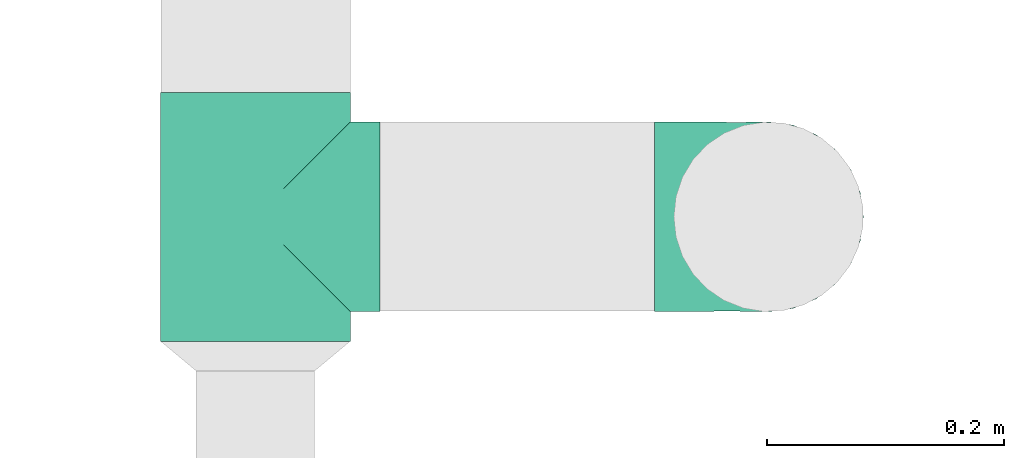
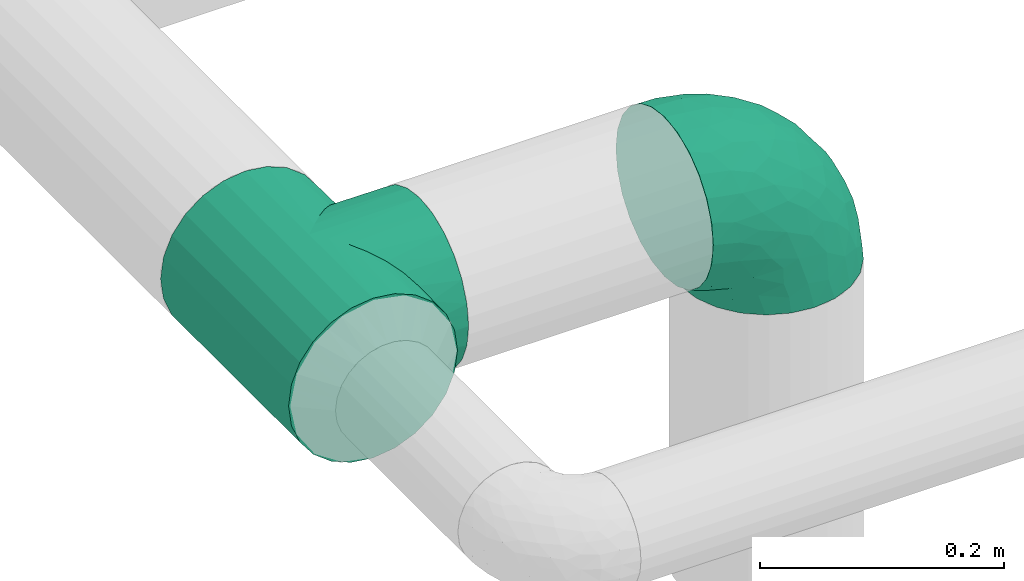
# One storey, part 3 of 12: 2 flow fittings.
"""IFC2X3 building model written with IfcOpenShell, lengths in millimetres."""

import ifcopenshell
import ifcopenshell.guid

model = None  # the IFC model being written
_history = None  # IfcOwnerHistory: only IFC2X3 demands one
_inside = {}  # id of a spatial element -> (the spatial element, [elements in it])
_under = {}  # id of a project, library or spatial element -> (it, [spatial elements below it])
_declared = {}  # id of a project -> (the project, [libraries it declares])
_typed = {}  # id of a type object -> (the type object, [elements of that type])
_made_of = {}  # id of a material, layer set ... -> (it, [elements and type objects made of it])


def new_model(schema):
    """Start an empty IFC model of exactly this schema.

    Asked for "IFC4X3", IfcOpenShell would pick the latest addendum, in which some entities
    have other attributes; the version numbers below select the first issue.
    IFC2X3 requires an IfcOwnerHistory on every rooted entity: one is made here for all.
    """
    global model, _history
    if schema == "IFC4X3":
        model = ifcopenshell.file(schema_version=(4, 3, 0, 0))
    else:
        model = ifcopenshell.file(schema=schema)
    _inside.clear()
    _under.clear()
    _declared.clear()
    _typed.clear()
    _made_of.clear()
    _history = None
    if model.schema == "IFC2X3":
        org = make("IfcOrganization", Name="unknown")
        user = make(
            "IfcPersonAndOrganization",
            ThePerson=make("IfcPerson", FamilyName="unknown"),
            TheOrganization=org,
        )
        app = make(
            "IfcApplication",
            ApplicationDeveloper=org,
            Version="unknown",
            ApplicationFullName="unknown",
            ApplicationIdentifier="unknown",
        )
        _history = make(
            "IfcOwnerHistory",
            OwningUser=user,
            OwningApplication=app,
            ChangeAction="ADDED",
            CreationDate=0,
        )
    return model


def make(cls, **values):
    """One entity of the class cls with the attributes given. An attribute that is None is left unset."""
    return model.create_entity(
        cls, **{name: value for name, value in values.items() if value is not None}
    )


def entity(cls, *values):
    """Any entity or typed value of the class cls, its attributes in the order of the schema. None: left unset."""
    e = model.create_entity(cls)
    for i, value in enumerate(values):
        if value is not None:
            e[i] = value
    return e


def rooted(cls, **values):
    """An entity with a GlobalId (a new one), such as an element, a storey or a relation."""
    return make(cls, GlobalId=ifcopenshell.guid.new(), OwnerHistory=_history, **values)


def si_unit(unit_type, name, prefix=None):
    """IfcSIUnit, for example si_unit("LENGTHUNIT", "METRE", prefix="MILLI")."""
    return make("IfcSIUnit", UnitType=unit_type, Prefix=prefix, Name=name)


def converted_unit(unit_type, name, factor, base, dimensions=None, offset=None):
    """IfcConversionBasedUnit, such as the inch: factor (a typed value) times the base unit."""
    return make(
        "IfcConversionBasedUnit"
        if offset is None
        else "IfcConversionBasedUnitWithOffset",
        ConversionOffset=offset,
        Dimensions=None
        if dimensions is None
        else entity("IfcDimensionalExponents", *dimensions),
        UnitType=unit_type,
        Name=name,
        ConversionFactor=make(
            "IfcMeasureWithUnit", ValueComponent=factor, UnitComponent=base
        ),
    )


def derived_unit(unit_type, elements):
    """IfcDerivedUnit: a product of units, each with its exponent."""
    return make(
        "IfcDerivedUnit",
        Elements=[
            make("IfcDerivedUnitElement", Unit=unit, Exponent=power)
            for unit, power in elements
        ],
        UnitType=unit_type,
    )


def assignment(units):
    """IfcUnitAssignment: the units of a project."""
    return None if units is None else make("IfcUnitAssignment", Units=units)


def point(xyz):
    """IfcCartesianPoint."""
    return None if xyz is None else make("IfcCartesianPoint", Coordinates=xyz)


def direction(xyz):
    """IfcDirection."""
    return None if xyz is None else make("IfcDirection", DirectionRatios=xyz)


def frame(location, z_axis=None, x_axis=None):
    """IfcAxis2Placement3D, a coordinate frame: its origin and axes. An axis left out is left unset."""
    return make(
        "IfcAxis2Placement3D",
        Location=point(location),
        Axis=direction(z_axis),
        RefDirection=direction(x_axis),
    )


def origin():
    """The frame at (0, 0, 0) with its axes left unset."""
    return frame((0.0, 0.0, 0.0))


def place(relative_to, where):
    """IfcLocalPlacement: puts the frame where relative to a parent placement (None: the world)."""
    return make(
        "IfcLocalPlacement", PlacementRelTo=relative_to, RelativePlacement=where
    )


def context(
    kind, dimensions, precision=None, world=None, true_north=None, identifier=None
):
    """IfcGeometricRepresentationContext, for example the 3D "Model" context."""
    return make(
        "IfcGeometricRepresentationContext",
        ContextIdentifier=identifier,
        ContextType=kind,
        CoordinateSpaceDimension=dimensions,
        Precision=precision,
        WorldCoordinateSystem=world,
        TrueNorth=true_north,
    )


def subcontext(parent, identifier, kind, view, scale=None):
    """IfcGeometricRepresentationSubContext, for example "Body" below "Model"."""
    return make(
        "IfcGeometricRepresentationSubContext",
        ContextIdentifier=identifier,
        ContextType=kind,
        ParentContext=parent,
        TargetScale=scale,
        TargetView=view,
    )


def project(units=None, contexts=None):
    """IfcProject with its units and contexts."""
    return rooted(
        "IfcProject",
        Name="project",
        RepresentationContexts=contexts,
        UnitsInContext=assignment(units),
    )


def spatial(cls, under=None, at=None, **own):
    """A site, building, storey or space (cls), placed at a placement, below another one or the project."""
    s = rooted(cls, ObjectPlacement=at, **own)
    if under is not None:
        _under.setdefault(under.id(), (under, []))[1].append(s)
    return s


def faces_of(points, faces, orient=None, outer=None):
    """IfcFace entities. A face is a list of loops; a loop is a list of indices into points, from 0.

    orient and outer hold one flag for each loop. By default every Orientation is true, the
    first loop of a face is its IfcFaceOuterBound and the others are IfcFaceBound.
    """
    made = []
    for i, loops in enumerate(faces):
        bounds = []
        for j, loop in enumerate(loops):
            is_outer = j == 0 if outer is None else outer[i][j]
            bounds.append(
                make(
                    "IfcFaceOuterBound" if is_outer else "IfcFaceBound",
                    Bound=make("IfcPolyLoop", Polygon=[points[k] for k in loop]),
                    Orientation=True if orient is None else orient[i][j],
                )
            )
        made.append(make("IfcFace", Bounds=bounds))
    return made


def faceted_brep(points, faces, orient=None, outer=None, voids=None):
    """IfcFacetedBrep: a solid bounded by flat faces; with voids (closed shells), ...WithVoids."""
    shared = [point(p) for p in points]
    hull = make("IfcClosedShell", CfsFaces=faces_of(shared, faces, orient, outer))
    if voids is None:
        return make("IfcFacetedBrep", Outer=hull)
    return make(
        "IfcFacetedBrepWithVoids",
        Outer=hull,
        Voids=[
            make(cls, CfsFaces=faces_of(shared, fs, o, b)) for cls, fs, o, b in voids
        ],
    )


def shape(context_of_items, identifier, shape_type, items):
    """IfcShapeRepresentation: the items that make up one representation, for example the "Body"."""
    return make(
        "IfcShapeRepresentation",
        ContextOfItems=context_of_items,
        RepresentationIdentifier=identifier,
        RepresentationType=shape_type,
        Items=items,
    )


def source(mapping_origin, context_of_items, identifier, shape_type, items):
    """IfcRepresentationMap: a shape defined once, which mapped items show again and again."""
    return make(
        "IfcRepresentationMap",
        MappingOrigin=mapping_origin,
        MappedRepresentation=shape(context_of_items, identifier, shape_type, items),
    )


def transform(
    local_origin,
    x_axis=None,
    y_axis=None,
    z_axis=None,
    scale=None,
    scale2=None,
    scale3=None,
    uniform=True,
):
    """IfcCartesianTransformationOperator3D, or its non-uniform kind. x_axis, y_axis, z_axis: its Axis1, 2, 3."""
    if uniform:
        return make(
            "IfcCartesianTransformationOperator3D",
            Axis1=direction(x_axis),
            Axis2=direction(y_axis),
            LocalOrigin=point(local_origin),
            Scale=scale,
            Axis3=direction(z_axis),
        )
    return make(
        "IfcCartesianTransformationOperator3DnonUniform",
        Axis1=direction(x_axis),
        Axis2=direction(y_axis),
        LocalOrigin=point(local_origin),
        Scale=scale,
        Axis3=direction(z_axis),
        Scale2=scale2,
        Scale3=scale3,
    )


def mapped(mapping_source, mapping_target):
    """IfcMappedItem: shows the shape of a source again, moved by a transform."""
    return make(
        "IfcMappedItem", MappingSource=mapping_source, MappingTarget=mapping_target
    )


def made_of(thing, what):
    """Note that an element or type object is made of a material, layer set ...; save() writes the relation."""
    if what is not None:
        _made_of.setdefault(what.id(), (what, []))[1].append(thing)
    return thing


def type_object(cls, material=None, **own):
    """A type object (cls), such as IfcWallType, which elements share."""
    return made_of(rooted(cls, **own), material)


def type_shapes(of_type, sources):
    """Give a type object the sources (RepresentationMaps) that its elements show as mapped items."""
    of_type.RepresentationMaps = sources


def element(
    cls,
    number,
    at=None,
    inside=None,
    cuts=None,
    type_object=None,
    material=None,
    context=None,
    identifier="Body",
    shape_type=None,
    held_by="IfcProductDefinitionShape",
    body=None,
    shapes=None,
    **own,
):
    """One element of the class cls, such as IfcWall. Its Tag is "e" and its number.

    at: its placement. inside: the storey or other place that contains it. cuts: it is an
    opening in that element (IfcRelVoidsElement). A single representation is given by context,
    identifier, shape_type and body (its items); several are given by shapes. held_by: the class
    of the entity that holds the representations. save() writes the other relations.
    """
    e = rooted(cls, Tag="e%d" % number, ObjectPlacement=at, **own)
    if body is not None:
        shapes = [shape(context, identifier, shape_type, body)]
    if shapes is not None:
        e.Representation = make(held_by, Representations=shapes)
    if inside is not None:
        _inside.setdefault(inside.id(), (inside, []))[1].append(e)
    if cuts is not None:
        rooted(
            "IfcRelVoidsElement", RelatingBuildingElement=cuts, RelatedOpeningElement=e
        )
    if type_object is not None:
        _typed.setdefault(type_object.id(), (type_object, []))[1].append(e)
    return made_of(e, material)


def aggregate(whole, parts):
    """IfcRelAggregates: a whole, such as a stair, and the parts it consists of."""
    return rooted("IfcRelAggregates", RelatingObject=whole, RelatedObjects=parts)


def save(model, path):
    """Write the relations noted so far, then the file.

    IfcRelAggregates (storeys below a building ...), IfcRelContainedInSpatialStructure (elements
    in a storey), IfcRelDefinesByType, IfcRelAssociatesMaterial and IfcRelDeclares: one each for
    every whole, place, type object, material and project.
    """
    for whole, parts in _under.values():
        aggregate(whole, parts)
    for where, things in _inside.values():
        rooted(
            "IfcRelContainedInSpatialStructure",
            RelatedElements=things,
            RelatingStructure=where,
        )
    for kind, things in _typed.values():
        rooted("IfcRelDefinesByType", RelatedObjects=things, RelatingType=kind)
    for what, things in _made_of.values():
        rooted("IfcRelAssociatesMaterial", RelatedObjects=things, RelatingMaterial=what)
    for by, libraries in _declared.values():
        rooted("IfcRelDeclares", RelatingContext=by, RelatedDefinitions=libraries)
    model.write(path)


model = new_model("IFC2X3")

# Units and contexts
model_context = context("Model", 3, precision=0.01, world=origin(), true_north=direction((6.12303176911189e-17, 1.0)))
body_context = subcontext(model_context, "Body", "Model", "MODEL_VIEW")
ifc_project = project(units=[si_unit("LENGTHUNIT", "METRE", prefix="MILLI"), si_unit("AREAUNIT", "SQUARE_METRE"), si_unit("VOLUMEUNIT", "CUBIC_METRE"), converted_unit("PLANEANGLEUNIT", "DEGREE", entity("IfcRatioMeasure", 0.0174532925199433), si_unit("PLANEANGLEUNIT", "RADIAN"), dimensions=[0, 0, 0, 0, 0, 0, 0]), si_unit("MASSUNIT", "GRAM", prefix="KILO"), derived_unit("MASSDENSITYUNIT", [(si_unit("MASSUNIT", "GRAM", prefix="KILO"), 1), (si_unit("LENGTHUNIT", "METRE"), -3)]), si_unit("TIMEUNIT", "SECOND"), si_unit("FREQUENCYUNIT", "HERTZ"), si_unit("THERMODYNAMICTEMPERATUREUNIT", "DEGREE_CELSIUS"), derived_unit("THERMALTRANSMITTANCEUNIT", [(si_unit("MASSUNIT", "GRAM", prefix="KILO"), 1), (si_unit("THERMODYNAMICTEMPERATUREUNIT", "KELVIN"), -1), (si_unit("TIMEUNIT", "SECOND"), -3)]), derived_unit("VOLUMETRICFLOWRATEUNIT", [(si_unit("LENGTHUNIT", "METRE"), 3), (si_unit("TIMEUNIT", "SECOND"), -1)]), si_unit("ELECTRICCURRENTUNIT", "AMPERE"), si_unit("ELECTRICVOLTAGEUNIT", "VOLT"), si_unit("POWERUNIT", "WATT"), si_unit("FORCEUNIT", "NEWTON", prefix="KILO"), si_unit("ILLUMINANCEUNIT", "LUX"), si_unit("LUMINOUSFLUXUNIT", "LUMEN"), si_unit("LUMINOUSINTENSITYUNIT", "CANDELA"), derived_unit("USERDEFINED", [(si_unit("MASSUNIT", "GRAM", prefix="KILO"), -1), (si_unit("LENGTHUNIT", "METRE"), -2), (si_unit("TIMEUNIT", "SECOND"), 3), (si_unit("LUMINOUSFLUXUNIT", "LUMEN"), 1)]), derived_unit("LINEARVELOCITYUNIT", [(si_unit("LENGTHUNIT", "METRE"), 1), (si_unit("TIMEUNIT", "SECOND"), -1)]), si_unit("PRESSUREUNIT", "PASCAL"), derived_unit("USERDEFINED", [(si_unit("LENGTHUNIT", "METRE"), -2), (si_unit("MASSUNIT", "GRAM", prefix="KILO"), 1), (si_unit("TIMEUNIT", "SECOND"), -2)])], contexts=[model_context])

# Site, building, storey
site_placement = place(None, origin())
site = spatial("IfcSite", under=ifc_project, at=site_placement, CompositionType="ELEMENT")
building_placement = place(site_placement, origin())
building = spatial("IfcBuilding", under=site, at=building_placement, CompositionType="ELEMENT")
storey_placement = place(building_placement, frame((0.0, 0.0, 4000.0)))
storey = spatial("IfcBuildingStorey", under=building, at=storey_placement, Name="01 Level", CompositionType="ELEMENT", Elevation=4000.0)

# Flow fittings
duct_fitting_type_1 = type_object("IfcDuctFittingType", Name="Air_Elbow short_Circ", PredefinedType="NOTDEFINED")
shared_shape_1 = source(origin(), body_context, "Body", "Brep", [
    faceted_brep([(-96.0, 40.0, -69.2820323027551), (-96.0, 20.7055236082018, -77.2740661031254), (-96.0, 0.0, -80.0), (-96.0, -20.7055236082015, -77.2740661031255), (-96.0, -40.0, -69.2820323027552), (-96.0, -56.5685424949237, -56.5685424949239), (-96.0, -69.282032302755, -40.0), (-96.0, -77.2740661031254, -20.7055236082019), (-96.0, -80.0, 0.0), (-96.0, -77.2740661031256, 20.7055236082014), (-96.0, -69.2820323027553, 40.0), (-96.0, -56.568542494924, 56.5685424949236), (-96.0, -40.0, 69.2820323027549), (-96.0, -20.705523608202, 77.2740661031254), (-96.0, 0.0, 80.0), (-96.0, 20.7055236082013, 77.2740661031256), (-96.0, 30.3527618041005, 73.2780492029404), (-96.0, 40.0, 69.2820323027553), (-96.0, 56.5685424949235, 56.5685424949241), (-96.0, 69.2820323027549, 40.0), (-96.0, 77.2740661031253, 20.7055236082021), (-96.0, 80.0, 0.0), (-96.0, 77.2740661031255, -20.7055236082016), (-96.0, 69.2820323027551, -40.0), (-96.0, 56.5685424949239, -56.5685424949238), (0.0, 96.0, -80.0), (-20.7055236082008, 96.0, -77.2740661031254), (-30.3527618041, 96.0, -73.2780492029402), (-40.0, 96.0, -69.2820323027551), (-56.5685424949229, 96.0, -56.5685424949238), (-69.2820323027542, 96.0, -40.0), (-77.2740661031245, 96.0, -20.7055236082016), (-80.0, 96.0, 0.0), (-77.2740661031244, 96.0, 20.7055236082021), (-69.2820323027539, 96.0, 40.0), (-56.5685424949226, 96.0, 56.5685424949241), (-40.0, 96.0, 69.2820323027553), (-20.7055236082004, 96.0, 77.2740661031256), (0.0, 96.0, 80.0), (20.7055236082029, 96.0, 77.2740661031254), (40.0, 96.0, 69.2820323027549), (56.5685424949249, 96.0, 56.5685424949236), (69.2820323027562, 96.0, 40.0), (77.2740661031265, 96.0, 20.7055236082014), (80.0, 96.0, 0.0), (77.2740661031264, 96.0, -20.7055236082019), (69.2820323027559, 96.0, -40.0), (56.5685424949246, 96.0, -56.5685424949239), (40.0, 96.0, -69.2820323027552), (20.7055236082025, 96.0, -77.2740661031255), (-69.6571465232348, 6.28172173912476, 79.9611058756859), (-55.1380888291464, -64.4450584799279, 39.5029426177976), (-78.4902527850466, -65.2482264041437, 44.9229732355936), (-66.7862289407348, -74.1387210661139, 22.9795507758541), (-79.9123689128389, 22.4151301859584, 77.2816866630488), (-75.1250134759213, 46.3506195730757, 68.0011973810265), (-46.2820694578435, -43.7397705581167, 60.5188244193914), (-62.9760666105318, -34.5362195419601, 70.0448030595901), (-67.1316735243184, -51.7530432423058, 58.5204707533666), (-50.4478480619551, -74.0029454268759, 0.0), (-76.2276812833835, -77.3969248578635, 0.0), (-27.189372084162, 68.980536479128, 76.8941402015288), (-6.30632028234235, 70.6421404093778, 79.9513108199466), (-47.7584488981354, -13.6212410427434, 76.3881123659885), (-29.8609237116382, -28.9682345099716, 65.8760199345924), (57.6005967886466, 33.4719572927763, 39.0176496769077), (51.7530435574228, 67.1316742002235, 58.5204705859065), (43.7397637815864, 46.2820598522933, 60.518827155348), (-74.2591571701267, -14.3645886695287, 78.2829835259588), (28.4507934888335, -28.4507934888321, 0.0), (23.3846344985257, -27.9066135199674, 24.7887114209846), (7.8513563843086, -42.4938374080907, 21.3232874317503), (-84.190871651952, 70.905997349447, 41.7100461919055), (24.7272484782103, -2.06889411058577, 53.4325037134459), (-0.0180155578363953, -25.9284255475521, 53.836744023285), (10.21505333872, -32.0754161621096, 38.020212353501), (-64.5619855594544, 27.52018553659, 77.2892967298799), (-41.7574890626937, 15.123136403511, 79.988056483004), (-24.5336756868846, -60.9669573051438, 23.5003835585885), (-29.2239240309769, -65.2117082464685, 0.0), (-8.0, -56.420471066061, 0.0), (-16.4008295437786, 51.3122057461681, 79.8609584412684), (-83.0529092063249, 83.0529092103045, 19.0855009657076), (-84.6862915010143, 84.6862915010152, 0.0), (-82.4185651555764, 62.2587017800419, 53.3339952483838), (-46.3022193149449, 75.902750025661, 67.8445262622594), (-9.5260688639158, -47.7232209131232, 35.4187162694583), (74.1387213421635, 66.7862279048973, 22.9795492840646), (14.3645870599314, 74.259154996167, 78.2829837700474), (34.536215572589, 62.976064096567, 70.0448048426748), (65.2482273833467, 78.4902510979302, 44.9229715327465), (-12.3935655196116, 25.4017250572252, 78.8652642576962), (-25.6317751341749, 1.2640655514879, 76.9124052095498), (69.8186739706361, 42.5625104806759, 16.7980672722629), (64.4450597015273, 55.1380839274934, 39.5029384026545), (60.9669574479924, 24.5336725945725, 23.5003789659965), (77.3969247188647, 76.2276802275763, 0.0), (74.002945426877, 50.4478480619565, 0.0), (-66.5995156060253, 66.5995146556305, 58.6370817132137), (-52.4774893100348, 53.0631556360015, 72.0041598972686), (-76.4857465466113, 78.9385356944492, 38.5867538667356), (-62.2587016209511, 82.4185645906685, 53.3339956492136), (28.9682276847195, 29.8609133580269, 65.8760207540895), (13.6212369177471, 47.7584433090926, 76.3881128402526), (-6.49930484510329, -53.7890406240985, 15.4645725223014), (-33.731289034344, 40.0214486160993, 79.0537019298314), (46.1336936566893, 26.2441492635858, 50.151541479116), (42.4356322774479, -10.225396744416, 0.0), (56.4204710660622, 8.0, 0.0), (50.0005984633279, 1.26038287501495, 17.5763945268078), (-45.4536887619888, -68.8356359385787, 23.6914879663761), (-33.3493864711472, -57.4572215948989, 39.1720709545353), (35.9683398342664, -11.0724559744972, 30.5391080332169), (-26.2441652621668, -46.1336984778153, 50.1515448602929), (36.6749123583047, -17.5982116941791, 14.5644188861001), (65.2117082464696, 29.2239240309784, 0.0), (49.5968730216335, 12.1440064858134, 34.8325942562253), (-47.1533280807863, 29.0746114834461, 78.9127210009486), (-0.981722938535007, 51.3162880079176, 79.4920802366619), (12.4951682569875, 20.0804783439543, 71.2292489374933), (-1.95170750213435, 1.95169859379814, 70.9272590604952), (13.0725391330592, 1.13338064801589, 63.5790506070627), (-1.93327092594732, -13.4823821925323, 63.7412032706882), (-18.9298205951927, -13.0048872663631, 70.6672094580024), (10.2253967444173, -42.4356322774466, 0.0), (-68.9805369123341, 27.1893702897943, -76.8941406355589), (-22.4151342180024, 79.9123577737124, -77.2816862456941), (-27.5201921618733, 64.5619784506715, -77.2892959136582), (-46.3506180288022, 75.1250185023919, -68.0011970559212), (-74.2591561090454, -14.364589592643, -78.2829832920378), (-42.5625109127564, -69.8186736490614, -16.7980693145318), (-66.78622820047, -74.1387209331735, -22.9795507950237), (-70.6421421271429, 6.30631801763141, -79.9513108797024), (-25.401718902627, 12.3935649209934, -78.8652635038296), (-15.1231475192353, 41.7574898106582, -79.9880566497423), (-1.2640784754681, 25.6317655571971, -76.9124065444174), (-78.9385361639639, 76.4857467527193, -38.5867530236755), (-66.5995166501766, 66.5995137008527, -58.6370816545605), (-82.4185656924104, 62.258701559575, -53.3339952529289), (60.9669567069012, 24.5336743104721, -23.5003834743896), (53.7890400497189, 6.49930371043273, -15.4645720709197), (-55.1380878256228, -64.4450583029017, -39.5029424837467), (-24.5336751436549, -60.9669572920351, -23.5003828649414), (-29.8609212227281, -28.9682353164184, -65.8760186412515), (-26.2441631797834, -46.1336980827234, -50.1515441608816), (-46.2820677406335, -43.7397707662098, -60.5188237522514), (74.1387206827049, 66.7862275406284, -22.9795512458422), (-40.0214489824224, 33.7312845774564, -79.0537024061946), (-78.4902524468744, -65.2482264004152, -44.9229731872606), (-75.902751427461, 46.3022186029078, -67.8445263463497), (-70.9059970555813, 84.1908706304995, -41.7100473389448), (-67.1316724627346, -51.7530434014037, -58.5204704180807), (-62.9760652707231, -34.536220162299, -70.044802546446), (-33.4719630839568, -57.6005950429912, -39.0176564793206), (-51.3122062597491, 16.4008248291117, -79.8609586691244), (-6.28171714934502, 69.65712797409, -79.9611061760713), (51.7530427306645, 67.1316703492073, -58.5204706539109), (-83.0529092397056, 83.0529091932979, -19.0855009185769), (68.8356349913375, 45.45368838847, -23.6914905340598), (-62.258701383479, 82.4185638376438, -53.3339962098694), (34.53621889603, 62.9760621802168, -70.0448028055675), (-1.26038544288408, -50.0005998980998, -17.5763953891677), (13.6212385978137, 47.75844096294, -76.3881120677864), (14.3645887716112, 74.2591526334116, -78.2829833202131), (65.2482261461557, 78.4902526871683, -44.9229735979605), (2.068884460932, -24.7272580800759, -53.4325021883878), (25.9284207554091, 0.0180077987247146, -53.8367428868672), (32.0754071702863, -10.2150656939878, -38.0202105656364), (47.723215348146, 9.52606271707191, -35.4187195087105), (27.9066094773716, -23.3846413342612, -24.7887058003424), (42.4938359077841, -7.8513587520169, -21.3232866357369), (28.9682309044935, 29.8609168472814, -65.8760199178674), (64.4450577206072, 55.1380878066959, -39.5029434692504), (-53.063150048133, 52.4774843719861, -72.0041634993662), (43.7397687897612, 46.2820667462245, -60.5188250739327), (-47.7584463040963, -13.6212426330217, -76.3881115880261), (57.4572201066452, 33.3493827160302, -39.1720708806551), (11.0724494499294, -35.9683446288498, -30.5391089716619), (46.1336964749623, 26.2441642243134, -50.1515465265606), (17.5982028158329, -36.6749194460897, -14.5644209948051), (-12.1440097531109, -49.5968729214507, -34.8325978072281), (-29.0746218055845, 47.1533256390974, -78.912719851915), (-51.3162911259858, 0.981717610547608, -79.4920798409907), (-20.0804667507281, -12.4951842966219, -71.2292388196267), (-1.95170139871169, 1.95169735730944, -70.9272563527003), (-1.13337124471279, -13.072540998247, -63.5790448193562), (13.4823844636247, 1.93327501577089, -63.7412039856557), (13.0048800657406, 18.9298191902065, -70.6672121474654)], [[[0, 1, 2, 3, 4, 5, 6, 7, 8, 9, 10, 11, 12, 13, 14, 15, 16, 17, 18, 19, 20, 21, 22, 23, 24]], [[25, 26, 27, 28, 29, 30, 31, 32, 33, 34, 35, 36, 37, 38, 39, 40, 41, 42, 43, 44, 45, 46, 47, 48, 49]], [[15, 14, 50]], [[51, 52, 53]], [[54, 55, 17]], [[56, 57, 58]], [[59, 53, 60]], [[37, 61, 62]], [[63, 57, 64]], [[65, 66, 67]], [[52, 11, 10]], [[58, 57, 12]], [[68, 14, 13]], [[69, 70, 71]], [[72, 20, 19]], [[57, 63, 68]], [[73, 74, 75]], [[76, 50, 77]], [[13, 12, 57]], [[17, 55, 18]], [[17, 16, 15, 54]], [[78, 79, 80]], [[81, 62, 61]], [[21, 82, 83]], [[57, 56, 64]], [[21, 20, 82]], [[84, 72, 19]], [[12, 11, 58]], [[19, 18, 84]], [[36, 85, 61]], [[75, 74, 86]], [[53, 9, 60]], [[53, 10, 9]], [[42, 87, 43]], [[66, 41, 40]], [[88, 89, 39]], [[42, 41, 90]], [[40, 39, 89]], [[91, 77, 92]], [[87, 42, 90]], [[93, 94, 95]], [[89, 66, 40]], [[87, 96, 43]], [[36, 35, 85]], [[93, 97, 87]], [[85, 98, 99]], [[33, 100, 34]], [[82, 100, 33]], [[100, 98, 101]], [[102, 89, 103]], [[83, 82, 32]], [[78, 80, 104]], [[36, 61, 37]], [[61, 85, 99]], [[105, 77, 91]], [[102, 106, 67]], [[35, 34, 101]], [[37, 62, 38]], [[107, 108, 109]], [[110, 51, 53]], [[88, 39, 38]], [[78, 110, 79]], [[59, 79, 110]], [[51, 110, 111]], [[75, 70, 112]], [[111, 86, 113]], [[107, 114, 69]], [[106, 102, 73]], [[115, 93, 95]], [[62, 88, 38]], [[115, 95, 108]], [[116, 95, 65]], [[95, 116, 109]], [[68, 50, 14]], [[76, 77, 117]], [[76, 117, 99]], [[84, 55, 98]], [[101, 85, 35]], [[98, 55, 99]], [[81, 61, 105]], [[62, 118, 88]], [[67, 66, 89]], [[90, 66, 94]], [[52, 58, 11]], [[58, 51, 111]], [[50, 63, 77]], [[92, 77, 63]], [[119, 91, 120]], [[81, 118, 62]], [[120, 121, 119]], [[73, 112, 116]], [[120, 122, 121]], [[123, 122, 120]], [[74, 64, 113]], [[92, 123, 120]], [[74, 113, 86]], [[73, 121, 122]], [[76, 99, 55]], [[61, 99, 105]], [[9, 8, 60]], [[96, 87, 97]], [[96, 44, 43]], [[89, 88, 103]], [[57, 68, 13]], [[50, 68, 63]], [[100, 101, 34]], [[85, 101, 98]], [[55, 84, 18]], [[72, 98, 100]], [[105, 91, 81]], [[118, 91, 103]], [[91, 118, 81]], [[88, 118, 103]], [[98, 72, 84]], [[72, 100, 82]], [[82, 20, 72]], [[32, 82, 33]], [[53, 52, 10]], [[58, 52, 51]], [[66, 90, 41]], [[87, 90, 94]], [[76, 55, 54]], [[15, 50, 54]], [[50, 76, 54]], [[110, 53, 59]], [[111, 110, 78]], [[78, 104, 86]], [[111, 113, 56]], [[78, 86, 111]], [[86, 71, 75]], [[70, 75, 71]], [[73, 75, 112]], [[104, 124, 71]], [[95, 109, 108]], [[70, 114, 112]], [[94, 65, 95]], [[114, 109, 112]], [[69, 114, 70]], [[109, 114, 107]], [[73, 116, 106]], [[112, 109, 116]], [[66, 65, 94]], [[106, 116, 65]], [[97, 93, 115]], [[86, 104, 71]], [[124, 104, 80]], [[124, 69, 71]], [[94, 93, 87]], [[102, 67, 89]], [[65, 67, 106]], [[111, 56, 58]], [[64, 56, 113]], [[77, 105, 117]], [[99, 117, 105]], [[123, 63, 64]], [[91, 92, 120]], [[63, 123, 92]], [[122, 64, 74]], [[64, 122, 123]], [[73, 122, 74]], [[73, 102, 121]], [[119, 121, 102]], [[102, 103, 119]], [[91, 119, 103]], [[0, 125, 1]], [[126, 127, 128]], [[3, 2, 129]], [[130, 59, 131]], [[1, 132, 2]], [[133, 134, 135]], [[136, 137, 138]], [[139, 108, 140]], [[23, 138, 24]], [[130, 141, 142]], [[23, 22, 136]], [[143, 144, 145]], [[146, 46, 45]], [[147, 134, 133]], [[131, 6, 148]], [[0, 24, 149]], [[131, 60, 7]], [[150, 31, 30]], [[151, 4, 152]], [[153, 151, 145]], [[5, 4, 151]], [[4, 3, 152]], [[154, 132, 125]], [[5, 148, 6]], [[26, 25, 155]], [[3, 129, 152]], [[6, 131, 7]], [[48, 47, 156]], [[21, 83, 157]], [[139, 158, 115]], [[32, 31, 157]], [[157, 136, 22]], [[30, 159, 150]], [[49, 48, 160]], [[124, 80, 161]], [[29, 159, 30]], [[28, 27, 26, 126]], [[149, 125, 0]], [[127, 155, 134]], [[160, 162, 163]], [[164, 47, 46]], [[29, 28, 128]], [[165, 166, 167]], [[49, 163, 25]], [[168, 167, 166]], [[1, 125, 132]], [[139, 115, 108]], [[69, 169, 170]], [[162, 160, 171]], [[156, 160, 48]], [[172, 164, 146]], [[149, 137, 173]], [[146, 96, 97]], [[160, 174, 171]], [[143, 152, 175]], [[156, 174, 160]], [[125, 149, 173]], [[126, 128, 28]], [[97, 115, 158]], [[157, 22, 21]], [[158, 172, 146]], [[146, 45, 96]], [[172, 158, 176]], [[167, 169, 177]], [[176, 168, 178]], [[124, 179, 69]], [[144, 143, 165]], [[79, 130, 142]], [[45, 44, 96]], [[79, 142, 80]], [[180, 142, 153]], [[142, 180, 161]], [[163, 155, 25]], [[181, 134, 147]], [[127, 181, 173]], [[159, 128, 137]], [[138, 149, 24]], [[137, 128, 173]], [[154, 125, 147]], [[132, 182, 129]], [[145, 151, 152]], [[148, 151, 141]], [[164, 156, 47]], [[156, 172, 176]], [[155, 162, 134]], [[135, 134, 162]], [[183, 133, 184]], [[154, 182, 132]], [[184, 185, 183]], [[165, 177, 180]], [[184, 186, 185]], [[187, 186, 184]], [[166, 171, 178]], [[135, 187, 184]], [[166, 178, 168]], [[165, 185, 186]], [[127, 173, 128]], [[125, 173, 147]], [[60, 131, 59]], [[60, 8, 7]], [[132, 129, 2]], [[152, 129, 175]], [[160, 163, 49]], [[155, 163, 162]], [[136, 138, 23]], [[149, 138, 137]], [[128, 159, 29]], [[150, 137, 136]], [[147, 133, 154]], [[182, 133, 175]], [[133, 182, 154]], [[129, 182, 175]], [[137, 150, 159]], [[150, 136, 157]], [[32, 157, 83]], [[157, 31, 150]], [[146, 164, 46]], [[156, 164, 172]], [[151, 148, 5]], [[131, 148, 141]], [[127, 126, 155]], [[26, 155, 126]], [[158, 146, 97]], [[176, 158, 139]], [[139, 140, 168]], [[176, 178, 174]], [[139, 168, 176]], [[168, 170, 167]], [[169, 167, 170]], [[165, 167, 177]], [[140, 107, 170]], [[142, 161, 80]], [[169, 179, 177]], [[141, 153, 142]], [[179, 161, 177]], [[69, 179, 169]], [[161, 179, 124]], [[165, 180, 144]], [[177, 161, 180]], [[151, 153, 141]], [[144, 180, 153]], [[59, 130, 79]], [[168, 140, 170]], [[107, 140, 108]], [[107, 69, 170]], [[141, 130, 131]], [[143, 145, 152]], [[153, 145, 144]], [[176, 174, 156]], [[171, 174, 178]], [[173, 181, 147]], [[127, 134, 181]], [[187, 162, 171]], [[133, 135, 184]], [[162, 187, 135]], [[186, 171, 166]], [[171, 186, 187]], [[165, 186, 166]], [[165, 143, 185]], [[183, 185, 143]], [[143, 175, 183]], [[133, 183, 175]]]),
])
type_shapes(duct_fitting_type_1, [shared_shape_1])
flow_fitting_1_placement = place(storey_placement, frame((23618.7604148601, -69795.234231492, 3000.0), z_axis=(0.0, -1.0, 0.0), x_axis=(0.0, 0.0, 1.0)))
element("IfcFlowFitting", 1, at=flow_fitting_1_placement, inside=storey, type_object=duct_fitting_type_1, Name="elbow_short_001:Air_Elbow short_Circ", ObjectType="elbow_short_001:Air_Elbow short_Circ", context=body_context, shape_type="MappedRepresentation", body=[
    mapped(shared_shape_1, transform((0.0, 0.0, 0.0), scale=1.0)),
])
duct_fitting_type_2 = type_object("IfcDuctFittingType", Name="Air_Tee 90_Circ", PredefinedType="NOTDEFINED")
shared_shape_2 = source(origin(), body_context, "Body", "Brep", [
    faceted_brep([(-105.0, 40.0, -69.2820323027551), (-105.0, 20.705523608202, -77.2740661031254), (-105.0, 0.0, -80.0), (-105.0, -20.7055236082013, -77.2740661031255), (-105.0, -40.0, -69.2820323027552), (-105.0, -48.2842712474615, -62.9252873988396), (-105.0, -56.5685424949234, -56.5685424949239), (-105.0, -62.9252873988391, -48.2842712474621), (-105.0, -69.2820323027547, -40.0), (-105.0, -73.2780492029399, -30.352761804101), (-105.0, -75.2760576530325, -25.5291427061515), (-105.0, -77.2740661031251, -20.7055236082019), (-105.0, -77.9555495773438, -15.5291427061515), (-105.0, -78.6370330515624, -10.3527618041011), (-105.0, -79.3185165257811, -5.17638090205062), (-105.0, -80.0, 0.0), (-105.0, -79.3185165257812, 5.17638090205005), (-105.0, -78.6370330515626, 10.3527618041003), (-105.0, -77.955549577344, 15.5291427061506), (-105.0, -77.2740661031254, 20.7055236082009), (-105.0, -75.2760576530329, 25.5291427061505), (-105.0, -73.2780492029403, 30.3527618041001), (-105.0, -69.2820323027552, 40.0), (-105.0, -62.9252873988397, 48.2842712474612), (-105.0, -56.5685424949241, 56.5685424949232), (-105.0, -48.2842712474623, 62.925287398839), (-105.0, -40.0, 69.2820323027547), (-105.0, -20.7055236082022, 77.2740661031253), (-105.0, 0.0, 80.0), (-105.0, 20.7055236082011, 77.2740661031257), (-105.0, 40.0, 69.2820323027556), (-105.0, 56.5685424949234, 56.5685424949245), (-105.0, 69.2820323027549, 40.0), (-105.0, 77.2740661031255, 20.7055236082026), (-105.0, 80.0, 0.0), (-105.0, 77.2740661031257, -20.7055236082016), (-105.0, 69.2820323027554, -40.0), (-105.0, 56.5685424949241, -56.5685424949238), (105.0, 0.0, -80.0), (105.0, 20.7055236082014, -77.2740661031254), (105.0, 40.0, -69.2820323027551), (105.0, 56.5685424949235, -56.5685424949238), (105.0, 69.2820323027547, -40.0), (105.0, 77.2740661031251, -20.7055236082016), (105.0, 80.0, 0.0), (105.0, 77.2740661031248, 20.7055236082026), (105.0, 69.2820323027542, 40.0), (105.0, 56.5685424949228, 56.5685424949245), (105.0, 40.0, 69.2820323027556), (105.0, 20.7055236082004, 77.2740661031257), (105.0, 0.0, 80.0), (105.0, -20.7055236082029, 77.2740661031253), (105.0, -40.0, 69.2820323027547), (105.0, -48.284271247463, 62.9252873988389), (105.0, -56.5685424949248, 56.5685424949232), (105.0, -62.9252873988403, 48.2842712474612), (105.0, -69.2820323027559, 40.0), (105.0, -73.278049202941, 30.3527618041001), (105.0, -75.2760576530335, 25.5291427061505), (105.0, -77.2740661031261, 20.7055236082009), (105.0, -77.9555495773447, 15.5291427061506), (105.0, -78.6370330515632, 10.3527618041003), (105.0, -79.3185165257818, 5.17638090205001), (105.0, -80.0, 0.0), (105.0, -79.3185165257817, -5.17638090205064), (105.0, -78.6370330515631, -10.3527618041011), (105.0, -77.9555495773445, -15.5291427061515), (105.0, -77.2740661031258, -20.7055236082019), (105.0, -75.2760576530332, -25.5291427061515), (105.0, -73.2780492029406, -30.352761804101), (105.0, -69.2820323027554, -40.0), (105.0, -62.9252873988397, -48.2842712474621), (105.0, -56.5685424949241, -56.5685424949239), (105.0, -48.2842712474622, -62.9252873988395), (105.0, -40.0, -69.2820323027552), (105.0, -20.7055236082019, -77.2740661031255), (78.227899039511, -78.2278990395113, 16.7450234954769), (78.6709242796332, -78.6709242796336, 12.5587676216076), (79.1139495197555, -79.1139495197558, 8.37251174773832), (76.9834675239615, -76.9834675239618, 20.5993372484815), (75.7390360084121, -75.7390360084124, 24.4536510014862), (-78.227899039511, -78.2278990395108, 16.7450234954769), (-76.9834675239616, -76.9834675239614, 20.5993372484815), (-75.7390360084121, -75.7390360084119, 24.4536510014861), (73.2501729773131, -73.2501729773134, 32.1622785074954), (56.6842556369154, -56.6842556369157, 56.452592171563), (61.2529055661489, -61.2529055661492, 50.9613067090927), (46.3970120620784, -46.3970120620786, 65.1714452172986), (65.8215554953824, -65.8215554953827, 45.4700212466224), (69.5358642363477, -69.5358642363481, 38.8161498770589), (-73.2501729773132, -73.250172977313, 32.1622785074954), (-78.6709242796333, -78.6709242796331, 12.5587676216076), (-79.5569747598778, -79.5569747598776, 4.18625587386907), (-79.1139495197555, -79.1139495197553, 8.37251174773832), (-46.3970120620785, -46.3970120620784, 65.1714452172985), (-56.6842556369155, -56.6842556369154, 56.452592171563), (-61.252905566149, -61.2529055661488, 50.9613067090927), (-65.8215554953824, -65.8215554953822, 45.4700212466225), (-80.0, -80.0, 0.0), (79.5569747598777, -79.5569747598781, 4.18625587386903), (80.0, -80.0, 0.0), (-35.3477594379945, -35.3477594379945, 71.7672341860383), (-69.5358642363478, -69.5358642363476, 38.8161498770589), (35.3477594379944, -35.3477594379946, 71.7672341860384), (11.9716475671883, -11.9716475671884, 79.0991760673083), (23.8067106814643, -23.8067106814644, 76.3756540170299), (0.0, 0.0, 80.0), (-11.9716475671884, -11.9716475671884, 79.0991760673083), (-23.8067106814644, -23.8067106814643, 76.3756540170299), (-61.2529055661488, -61.2529055661486, -50.9613067090929), (-79.5569747598777, -79.5569747598776, -4.18625587386946), (79.5569747598777, -79.5569747598781, -4.18625587386948), (-75.739036008412, -75.7390360084118, -24.4536510014865), (-76.9834675239615, -76.9834675239613, -20.5993372484819), (-78.2278990395109, -78.2278990395108, -16.7450234954772), (0.0, 0.0, -80.0), (-79.1139495197555, -79.1139495197553, -8.3725117477387), (11.971647567188, -11.9716475671882, -79.0991760673083), (-11.9716475671881, -11.9716475671881, -79.0991760673083), (23.806710681464, -23.8067106814643, -76.3756540170299), (-65.8215554953822, -65.8215554953821, -45.4700212466227), (46.3970120620782, -46.3970120620784, -65.1714452172987), (65.8215554953821, -65.8215554953824, -45.4700212466228), (61.2529055661487, -61.252905566149, -50.961306709093), (79.1139495197555, -79.1139495197558, -8.37251174773877), (78.6709242796332, -78.6709242796335, -12.558767621608), (75.7390360084119, -75.7390360084122, -24.4536510014866), (-73.250172977313, -73.2501729773128, -32.1622785074957), (-56.6842556369153, -56.6842556369152, -56.4525921715632), (-46.3970120620782, -46.3970120620781, -65.1714452172987), (-23.8067106814641, -23.8067106814641, -76.37565401703), (-35.3477594379943, -35.3477594379942, -71.7672341860385), (35.3477594379942, -35.3477594379944, -71.7672341860385), (56.6842556369152, -56.6842556369155, -56.4525921715632), (78.2278990395109, -78.2278990395112, -16.7450234954773), (76.9834675239614, -76.9834675239618, -20.5993372484819), (-69.5358642363476, -69.5358642363474, -38.8161498770592), (73.250172977313, -73.2501729773133, -32.1622785074958), (-78.6709242796332, -78.670924279633, -12.5587676216079), (69.5358642363476, -69.5358642363478, -38.8161498770593), (0.0, -105.0, -80.0), (20.7055236082017, -105.0, -77.2740661031254), (40.0, -105.0, -69.2820323027551), (56.5685424949238, -105.0, -56.5685424949238), (69.2820323027551, -105.0, -40.0), (73.2780492029403, -105.0, -30.3527618041008), (77.2740661031254, -105.0, -20.7055236082016), (78.6370330515627, -105.0, -10.3527618041008), (80.0, -105.0, 0.0), (78.6370330515626, -105.0, 10.3527618041016), (77.2740661031252, -105.0, 20.7055236082026), (73.2780492029399, -105.0, 30.3527618041017), (69.2820323027546, -105.0, 40.0), (56.5685424949231, -105.0, 56.5685424949245), (40.0, -105.0, 69.2820323027556), (20.7055236082008, -105.0, 77.2740661031257), (0.0, -105.0, 80.0), (-20.7055236082025, -105.0, 77.2740661031253), (-40.0, -105.0, 69.2820323027547), (-56.5685424949244, -105.0, 56.5685424949232), (-69.2820323027555, -105.0, 40.0), (-73.2780492029406, -105.0, 30.3527618041001), (-77.2740661031257, -105.0, 20.7055236082009), (-78.6370330515629, -105.0, 10.3527618041003), (-80.0, -105.0, 0.0), (-78.6370330515627, -105.0, -10.352761804101), (-77.2740661031254, -105.0, -20.7055236082019), (-73.2780492029402, -105.0, -30.352761804101), (-69.282032302755, -105.0, -40.0), (-56.5685424949237, -105.0, -56.5685424949239), (-40.0, -105.0, -69.2820323027552), (-20.7055236082016, -105.0, -77.2740661031255)], [[[0, 1, 2, 3, 4, 5, 6, 7, 8, 9, 10, 11, 12, 13, 14, 15, 16, 17, 18, 19, 20, 21, 22, 23, 24, 25, 26, 27, 28, 29, 30, 31, 32, 33, 34, 35, 36, 37]], [[38, 39, 40, 41, 42, 43, 44, 45, 46, 47, 48, 49, 50, 51, 52, 53, 54, 55, 56, 57, 58, 59, 60, 61, 62, 63, 64, 65, 66, 67, 68, 69, 70, 71, 72, 73, 74, 75]], [[60, 59, 76]], [[77, 60, 76]], [[62, 61, 78]], [[79, 76, 59, 80]], [[19, 81, 82, 83]], [[57, 56, 84]], [[54, 85, 86]], [[87, 53, 52]], [[80, 57, 84]], [[88, 55, 86]], [[85, 54, 53]], [[85, 53, 87]], [[56, 88, 89, 84]], [[57, 80, 59, 58]], [[90, 21, 83]], [[91, 81, 18]], [[16, 92, 93]], [[54, 86, 55]], [[61, 77, 78]], [[20, 19, 83, 21]], [[81, 19, 18]], [[88, 56, 55]], [[94, 25, 95]], [[24, 23, 96]], [[97, 23, 22]], [[95, 25, 24]], [[92, 15, 98]], [[63, 99, 100]], [[26, 94, 101]], [[97, 22, 90, 102]], [[99, 63, 62]], [[23, 97, 96]], [[87, 52, 103]], [[51, 50, 104]], [[18, 17, 91]], [[105, 103, 51]], [[104, 105, 51]], [[24, 96, 95]], [[104, 50, 106]], [[107, 106, 28]], [[51, 103, 52]], [[32, 31, 47, 46]], [[33, 32, 46, 45]], [[30, 29, 49, 48]], [[31, 30, 48, 47]], [[49, 29, 28, 106, 50]], [[34, 33, 45, 44]], [[90, 22, 21]], [[108, 107, 27]], [[108, 27, 101]], [[27, 107, 28]], [[17, 93, 91]], [[101, 27, 26]], [[94, 26, 25]], [[15, 92, 16]], [[62, 78, 99]], [[93, 17, 16]], [[60, 77, 61]], [[6, 109, 7]], [[15, 110, 98]], [[111, 63, 100]], [[11, 112, 113, 114]], [[112, 11, 10, 9]], [[41, 37, 36, 42]], [[36, 35, 43, 42]], [[0, 37, 41, 40]], [[34, 44, 43, 35]], [[115, 2, 1, 39, 38]], [[14, 116, 110]], [[117, 38, 75]], [[110, 15, 14]], [[117, 115, 38]], [[2, 115, 118]], [[119, 117, 75]], [[120, 8, 7]], [[121, 74, 73]], [[40, 39, 1, 0]], [[71, 122, 123]], [[65, 124, 125]], [[126, 69, 68, 67]], [[124, 65, 64]], [[112, 9, 127]], [[128, 5, 129]], [[130, 131, 3]], [[118, 130, 3]], [[2, 118, 3]], [[131, 4, 3]], [[119, 75, 132]], [[72, 133, 73]], [[67, 134, 135, 126]], [[121, 73, 133]], [[72, 71, 123]], [[8, 120, 136, 127]], [[71, 70, 122]], [[74, 121, 132]], [[111, 124, 64]], [[137, 69, 126]], [[66, 125, 134]], [[138, 12, 114]], [[63, 111, 64]], [[70, 137, 139, 122]], [[13, 138, 116]], [[137, 70, 69]], [[66, 65, 125]], [[128, 6, 5]], [[129, 4, 131]], [[129, 5, 4]], [[109, 120, 7]], [[109, 6, 128]], [[72, 123, 133]], [[134, 67, 66]], [[14, 13, 116]], [[127, 9, 8]], [[11, 114, 12]], [[12, 138, 13]], [[74, 132, 75]], [[140, 141, 142, 143, 144, 145, 146, 147, 148, 149, 150, 151, 152, 153, 154, 155, 156, 157, 158, 159, 160, 161, 162, 163, 164, 165, 166, 167, 168, 169, 170, 171]], [[163, 162, 81]], [[164, 93, 92, 98]], [[164, 163, 93]], [[162, 90, 83, 82, 81]], [[159, 158, 94]], [[97, 160, 159]], [[90, 162, 161, 160]], [[101, 158, 157]], [[163, 81, 91, 93]], [[160, 97, 102, 90]], [[94, 95, 159]], [[159, 95, 96, 97]], [[108, 101, 157]], [[156, 106, 107]], [[108, 157, 107]], [[94, 158, 101]], [[84, 152, 151, 150]], [[107, 157, 156]], [[154, 103, 155]], [[155, 104, 156]], [[87, 154, 153]], [[148, 100, 99, 78]], [[153, 152, 88]], [[149, 78, 77, 76]], [[87, 103, 154]], [[105, 104, 155]], [[103, 105, 155]], [[150, 76, 79, 80, 84]], [[76, 150, 149]], [[153, 88, 86, 85]], [[148, 78, 149]], [[152, 84, 89, 88]], [[87, 153, 85]], [[156, 104, 106]], [[147, 146, 134]], [[127, 168, 167, 166]], [[148, 147, 124]], [[146, 137, 126, 135, 134]], [[137, 146, 145, 144]], [[147, 134, 125, 124]], [[122, 144, 143]], [[148, 124, 111, 100]], [[143, 142, 121]], [[132, 142, 141]], [[144, 122, 139, 137]], [[121, 133, 143]], [[143, 133, 123, 122]], [[119, 132, 141]], [[140, 115, 117]], [[119, 141, 117]], [[121, 142, 132]], [[164, 116, 165]], [[117, 141, 140]], [[170, 131, 171]], [[171, 118, 140]], [[129, 170, 169]], [[164, 98, 110, 116]], [[169, 168, 120]], [[165, 116, 138, 114]], [[129, 131, 170]], [[130, 118, 171]], [[131, 130, 171]], [[114, 166, 165]], [[166, 114, 113, 112, 127]], [[169, 120, 109, 128]], [[168, 127, 136, 120]], [[129, 169, 128]], [[140, 118, 115]]]),
])
type_shapes(duct_fitting_type_2, [shared_shape_2])
flow_fitting_2_placement = place(storey_placement, frame((23185.9900708518, -69795.234231492, 3000.0), z_axis=(0.0, 0.0, 1.0), x_axis=(0.0, 1.0, 0.0)))
element("IfcFlowFitting", 2, at=flow_fitting_2_placement, inside=storey, type_object=duct_fitting_type_2, Name="tee_90_001:Air_Tee 90_Circ", ObjectType="tee_90_001:Air_Tee 90_Circ", context=body_context, shape_type="MappedRepresentation", body=[
    mapped(shared_shape_2, transform((0.0, 0.0, 0.0), scale=1.0)),
])

save(model, "model.ifc")
